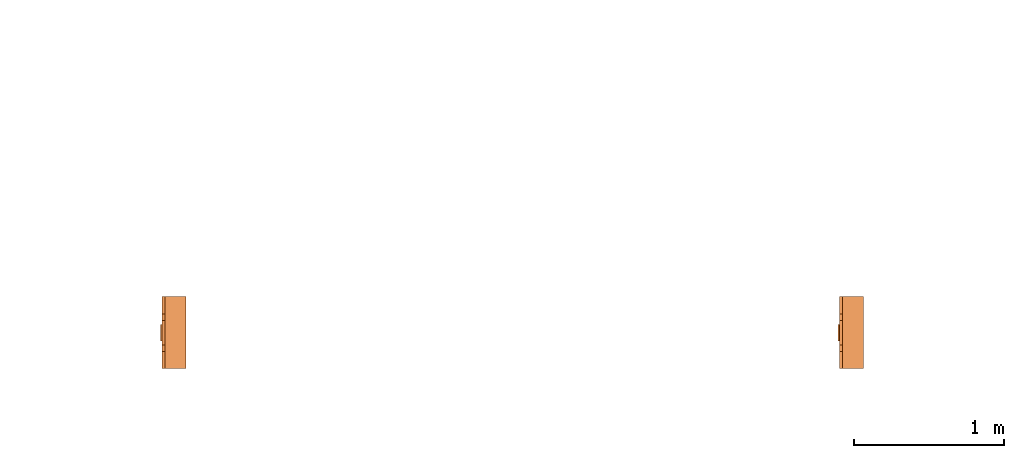
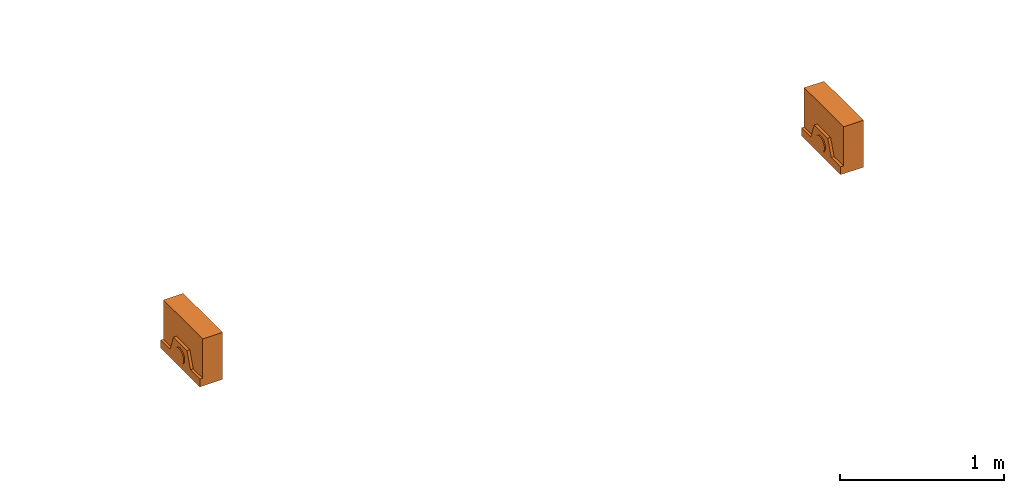
# One storey, part 2 of 5: 2 proxies.
"""IFC2X3 building model written with IfcOpenShell, lengths in millimetres."""

from ifc_helpers import new_model, entity, si_unit, converted_unit, derived_unit, direction, frame, origin, place, context, subcontext, project, spatial, faceted_brep, source, transform, mapped, material, material_list, type_object, type_shapes, element, save


model = new_model("IFC2X3")

# Units and contexts
model_context = context("Model", 3, precision=0.01, world=origin(), true_north=direction((6.12303176911189e-17, 1.0)))
body_context = subcontext(model_context, "Body", "Model", "MODEL_VIEW")
ifc_project = project(units=[si_unit("LENGTHUNIT", "METRE", prefix="MILLI"), si_unit("AREAUNIT", "SQUARE_METRE"), si_unit("VOLUMEUNIT", "CUBIC_METRE"), converted_unit("PLANEANGLEUNIT", "DEGREE", entity("IfcRatioMeasure", 0.0174532925199433), si_unit("PLANEANGLEUNIT", "RADIAN"), dimensions=[0, 0, 0, 0, 0, 0, 0]), si_unit("MASSUNIT", "GRAM", prefix="KILO"), derived_unit("MASSDENSITYUNIT", [(si_unit("MASSUNIT", "GRAM", prefix="KILO"), 1), (si_unit("LENGTHUNIT", "METRE"), -3)]), derived_unit("MOMENTOFINERTIAUNIT", [(si_unit("LENGTHUNIT", "METRE"), 4)]), si_unit("TIMEUNIT", "SECOND"), si_unit("FREQUENCYUNIT", "HERTZ"), si_unit("THERMODYNAMICTEMPERATUREUNIT", "DEGREE_CELSIUS"), derived_unit("THERMALTRANSMITTANCEUNIT", [(si_unit("MASSUNIT", "GRAM", prefix="KILO"), 1), (si_unit("THERMODYNAMICTEMPERATUREUNIT", "KELVIN"), -1), (si_unit("TIMEUNIT", "SECOND"), -3)]), derived_unit("VOLUMETRICFLOWRATEUNIT", [(si_unit("LENGTHUNIT", "METRE"), 3), (si_unit("TIMEUNIT", "SECOND"), -1)]), derived_unit("MASSFLOWRATEUNIT", [(si_unit("MASSUNIT", "GRAM", prefix="KILO"), 1), (si_unit("TIMEUNIT", "SECOND"), -1)]), derived_unit("ROTATIONALFREQUENCYUNIT", [(si_unit("TIMEUNIT", "SECOND"), -1)]), si_unit("ELECTRICCURRENTUNIT", "AMPERE"), si_unit("ELECTRICVOLTAGEUNIT", "VOLT"), si_unit("POWERUNIT", "WATT"), si_unit("FORCEUNIT", "NEWTON", prefix="KILO"), si_unit("ILLUMINANCEUNIT", "LUX"), si_unit("LUMINOUSFLUXUNIT", "LUMEN"), si_unit("LUMINOUSINTENSITYUNIT", "CANDELA"), derived_unit("USERDEFINED", [(si_unit("MASSUNIT", "GRAM", prefix="KILO"), -1), (si_unit("LENGTHUNIT", "METRE"), -2), (si_unit("TIMEUNIT", "SECOND"), 3), (si_unit("LUMINOUSFLUXUNIT", "LUMEN"), 1)]), derived_unit("LINEARVELOCITYUNIT", [(si_unit("LENGTHUNIT", "METRE"), 1), (si_unit("TIMEUNIT", "SECOND"), -1)]), si_unit("PRESSUREUNIT", "PASCAL"), derived_unit("USERDEFINED", [(si_unit("LENGTHUNIT", "METRE"), -2), (si_unit("MASSUNIT", "GRAM", prefix="KILO"), 1), (si_unit("TIMEUNIT", "SECOND"), -2)]), derived_unit("LINEARFORCEUNIT", [(si_unit("MASSUNIT", "GRAM", prefix="KILO"), 1), (si_unit("LENGTHUNIT", "METRE"), 1), (si_unit("TIMEUNIT", "SECOND"), -2), (si_unit("LENGTHUNIT", "METRE"), -1)]), derived_unit("PLANARFORCEUNIT", [(si_unit("MASSUNIT", "GRAM", prefix="KILO"), 1), (si_unit("LENGTHUNIT", "METRE"), 1), (si_unit("TIMEUNIT", "SECOND"), -2), (si_unit("LENGTHUNIT", "METRE"), -2)])], contexts=[model_context])

# Site, building, storey
site_placement = place(None, frame((0.0, 2493.83037508239, 0.0)))
site = spatial("IfcSite", under=ifc_project, at=site_placement, CompositionType="ELEMENT")
building_placement = place(site_placement, origin())
building = spatial("IfcBuilding", under=site, at=building_placement, CompositionType="ELEMENT")
storey_placement = place(building_placement, frame((0.0, 0.0, 19800.0)))
storey = spatial("IfcBuildingStorey", under=building, at=storey_placement, Name="06", CompositionType="ELEMENT", Elevation=19800.0)

# Proxies
ifc_material_1 = material()
ifc_material_2 = material()
ifc_material_list_1 = material_list([ifc_material_1, ifc_material_2])
building_element_proxy_type = type_object("IfcBuildingElementProxyType", PredefinedType="NOTDEFINED", material=ifc_material_1)
shared_shape = source(origin(), body_context, "Body", "Brep", [
    faceted_brep([(168.201612490282, 212.500000000001, 135.54049916809), (168.201612490282, 201.109127034741, 126.799974925206), (168.201612490282, 192.368602791857, 115.409101959946), (168.201612490282, 186.874079554102, 102.144149440585), (168.201612490282, 185.0, 87.9091019599461), (168.201612490282, 186.874079554102, 73.6740544793074), (168.201612490282, 192.368602791856, 60.4091019599461), (168.201612490282, 201.10912703474, 49.0182289946861), (168.201612490282, 212.500000000001, 40.2777047518019), (168.201612490282, 225.764952519362, 34.7831815140474), (168.201612490282, 240.0, 32.9091019599461), (168.201612490282, 254.235047480639, 34.7831815140472), (168.201612490282, 267.5, 40.2777047518019), (168.201612490282, 278.890872965261, 49.0182289946858), (168.201612490282, 287.631397208145, 60.4091019599458), (168.201612490282, 293.125920445899, 73.6740544793071), (168.201612490282, 295.0, 87.9091019599458), (168.201612490282, 293.125920445899, 102.144149440584), (168.201612490282, 287.631397208145, 115.409101959946), (168.201612490282, 278.890872965261, 126.799974925206), (168.201612490282, 267.500000000001, 135.54049916809), (168.201612490282, 254.235047480639, 141.035022405845), (168.201612490282, 240.0, 142.909101959946), (168.201612490282, 225.764952519362, 141.035022405845), (160.0, 225.764952519362, 34.7831815140474), (160.0, 212.500000000001, 40.2777047518019), (160.0, 201.10912703474, 49.0182289946861), (160.0, 192.368602791856, 60.4091019599461), (160.0, 186.874079554102, 73.6740544793074), (160.0, 185.0, 87.9091019599463), (160.0, 186.874079554102, 102.144149440585), (160.0, 192.368602791857, 115.409101959946), (160.0, 201.109127034741, 126.799974925206), (160.0, 212.500000000001, 135.54049916809), (160.0, 225.764952519362, 141.035022405845), (160.0, 240.0, 142.909101959946), (160.0, 254.235047480639, 141.035022405845), (160.0, 267.500000000001, 135.54049916809), (160.0, 278.890872965261, 126.799974925206), (160.0, 287.631397208145, 115.409101959946), (160.0, 293.125920445899, 102.144149440584), (160.0, 295.0, 87.9091019599458), (160.0, 293.125920445899, 73.6740544793071), (160.0, 287.631397208145, 60.4091019599458), (160.0, 278.890872965261, 49.0182289946858), (160.0, 267.5, 40.2777047518019), (160.0, 254.235047480639, 34.7831815140472), (160.0, 240.0, 32.9091019599461)], [[[0, 1, 2, 3, 4, 5, 6, 7, 8, 9, 10, 11, 12, 13, 14, 15, 16, 17, 18, 19, 20, 21, 22, 23]], [[24, 25, 26, 27, 28, 29, 30, 31, 32, 33, 34, 35, 36, 37, 38, 39, 40, 41, 42, 43, 44, 45, 46, 47]], [[40, 17, 16, 41]], [[39, 18, 17, 40]], [[20, 19, 38, 37]], [[39, 38, 19, 18]], [[21, 20, 37, 36]], [[22, 21, 36, 35]], [[34, 23, 22, 35]], [[33, 0, 23, 34]], [[2, 1, 32, 31]], [[33, 32, 1, 0]], [[3, 2, 31, 30]], [[4, 3, 30, 29]], [[28, 5, 4, 29]], [[27, 6, 5, 28]], [[8, 7, 26, 25]], [[27, 26, 7, 6]], [[9, 8, 25, 24]], [[10, 9, 24, 47]], [[46, 11, 10, 47]], [[45, 12, 11, 46]], [[14, 13, 44, 43]], [[45, 44, 13, 12]], [[15, 14, 43, 42]], [[16, 15, 42, 41]]]),
    faceted_brep([(160.0, 0.0, 0.0), (160.0, 480.0, 0.0), (160.0, 480.0, 58.2870579365997), (160.0, 365.0, 58.2870579366005), (160.0, 322.247482084292, 175.748635534839), (160.0, 157.75251791571, 175.748635534839), (160.0, 115.0, 58.2870579366), (160.0, 0.0, 58.2870579365997), (0.0, 480.0, 0.0), (0.0, 0.0, 0.0), (0.0, 0.0, 350.0), (0.0, 480.0, 350.0), (140.211167148102, 480.0, 350.0), (140.211167148102, 480.0, 58.2870579365997), (140.211167148102, 0.0, 350.0), (140.211167148102, 0.0, 58.2870579365997), (140.211167148102, 365.0, 58.2870579366), (140.211167148102, 115.0, 58.2870579366), (140.211167148102, 157.75251791571, 175.748635534839), (140.211167148102, 322.247482084292, 175.748635534839)], [[[0, 1, 2, 3, 4, 5, 6, 7]], [[8, 9, 10, 11]], [[8, 11, 12, 13, 2, 1]], [[11, 10, 14, 12]], [[10, 9, 0, 7, 15, 14]], [[1, 0, 9, 8]], [[16, 13, 12, 14, 15, 17, 18, 19]], [[13, 16, 3, 2]], [[17, 15, 7, 6]], [[18, 17, 6, 5]], [[19, 18, 5, 4]], [[16, 19, 4, 3]]]),
])
type_shapes(building_element_proxy_type, [shared_shape])
proxy_1_placement = place(storey_placement, frame((62280.1085349233, -16.3303750823849, 1500.0), z_axis=(0.0, 0.0, 1.0), x_axis=(-1.0, 0.0, 0.0)))
element("IfcBuildingElementProxy", 1, at=proxy_1_placement, inside=storey, type_object=building_element_proxy_type, material=ifc_material_list_1, context=body_context, shape_type="MappedRepresentation", body=[
    mapped(shared_shape, transform((0.0, 0.0, 0.0), scale=1.0)),
])
ifc_material_list_2 = material_list([ifc_material_1, ifc_material_2])
proxy_2_placement = place(storey_placement, frame((57764.8741661336, -16.3303750823753, 1500.0), z_axis=(0.0, 0.0, 1.0), x_axis=(-1.0, 0.0, 0.0)))
element("IfcBuildingElementProxy", 2, at=proxy_2_placement, inside=storey, type_object=building_element_proxy_type, material=ifc_material_list_2, context=body_context, shape_type="MappedRepresentation", body=[
    mapped(shared_shape, transform((0.0, 0.0, 0.0), scale=1.0)),
])

save(model, "model.ifc")
